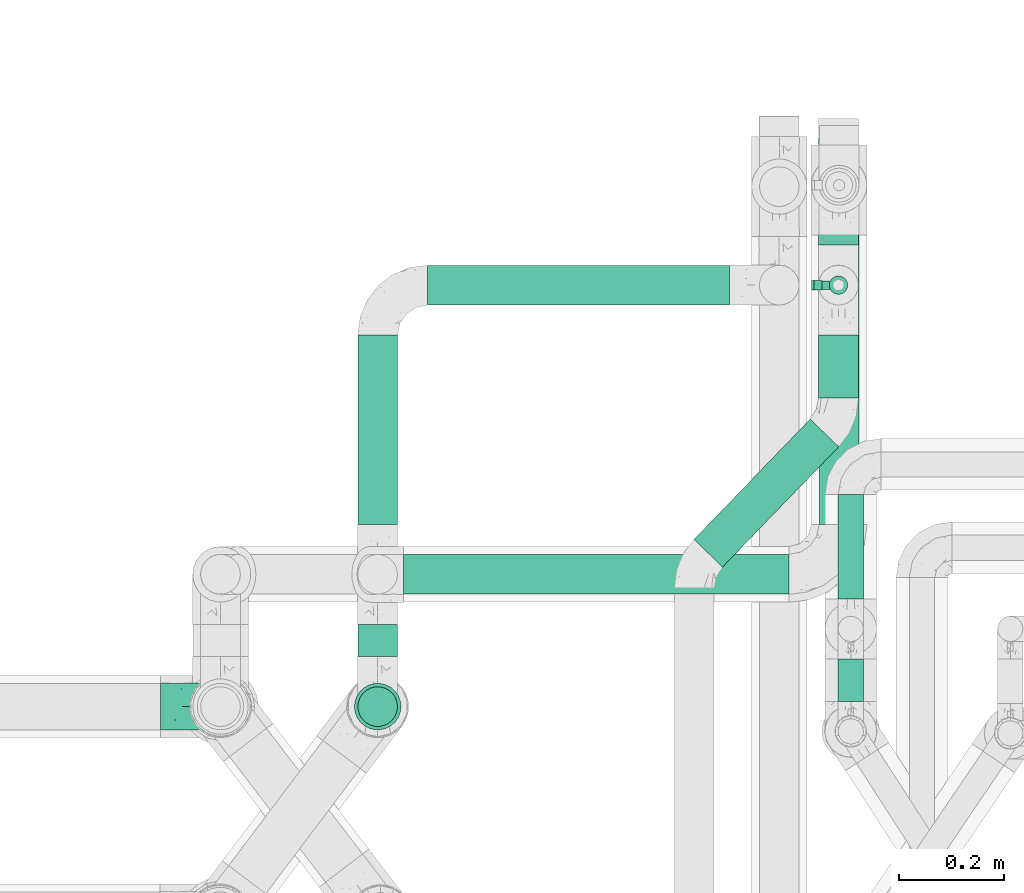
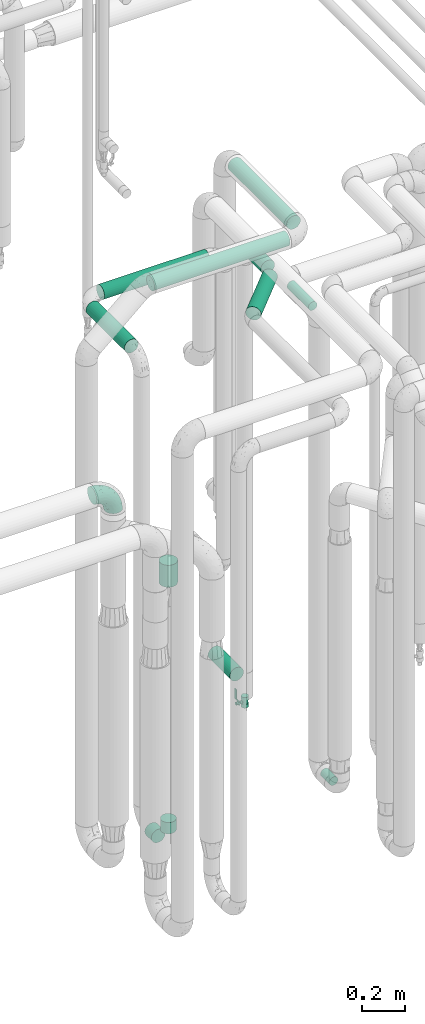
# One storey, part 670 of 827: 12 flow segments, 1 flow controller, 1 flow fitting.
"""IFC2X3 building model written with IfcOpenShell, lengths in millimetres."""

import ifcopenshell
import ifcopenshell.guid

model = None  # the IFC model being written
_history = None  # IfcOwnerHistory: only IFC2X3 demands one
_inside = {}  # id of a spatial element -> (the spatial element, [elements in it])
_under = {}  # id of a project, library or spatial element -> (it, [spatial elements below it])
_declared = {}  # id of a project -> (the project, [libraries it declares])
_typed = {}  # id of a type object -> (the type object, [elements of that type])
_made_of = {}  # id of a material, layer set ... -> (it, [elements and type objects made of it])


def new_model(schema):
    """Start an empty IFC model of exactly this schema.

    Asked for "IFC4X3", IfcOpenShell would pick the latest addendum, in which some entities
    have other attributes; the version numbers below select the first issue.
    IFC2X3 requires an IfcOwnerHistory on every rooted entity: one is made here for all.
    """
    global model, _history
    if schema == "IFC4X3":
        model = ifcopenshell.file(schema_version=(4, 3, 0, 0))
    else:
        model = ifcopenshell.file(schema=schema)
    _inside.clear()
    _under.clear()
    _declared.clear()
    _typed.clear()
    _made_of.clear()
    _history = None
    if model.schema == "IFC2X3":
        org = make("IfcOrganization", Name="unknown")
        user = make(
            "IfcPersonAndOrganization",
            ThePerson=make("IfcPerson", FamilyName="unknown"),
            TheOrganization=org,
        )
        app = make(
            "IfcApplication",
            ApplicationDeveloper=org,
            Version="unknown",
            ApplicationFullName="unknown",
            ApplicationIdentifier="unknown",
        )
        _history = make(
            "IfcOwnerHistory",
            OwningUser=user,
            OwningApplication=app,
            ChangeAction="ADDED",
            CreationDate=0,
        )
    return model


def make(cls, **values):
    """One entity of the class cls with the attributes given. An attribute that is None is left unset."""
    return model.create_entity(
        cls, **{name: value for name, value in values.items() if value is not None}
    )


def entity(cls, *values):
    """Any entity or typed value of the class cls, its attributes in the order of the schema. None: left unset."""
    e = model.create_entity(cls)
    for i, value in enumerate(values):
        if value is not None:
            e[i] = value
    return e


def rooted(cls, **values):
    """An entity with a GlobalId (a new one), such as an element, a storey or a relation."""
    return make(cls, GlobalId=ifcopenshell.guid.new(), OwnerHistory=_history, **values)


def si_unit(unit_type, name, prefix=None):
    """IfcSIUnit, for example si_unit("LENGTHUNIT", "METRE", prefix="MILLI")."""
    return make("IfcSIUnit", UnitType=unit_type, Prefix=prefix, Name=name)


def converted_unit(unit_type, name, factor, base, dimensions=None, offset=None):
    """IfcConversionBasedUnit, such as the inch: factor (a typed value) times the base unit."""
    return make(
        "IfcConversionBasedUnit"
        if offset is None
        else "IfcConversionBasedUnitWithOffset",
        ConversionOffset=offset,
        Dimensions=None
        if dimensions is None
        else entity("IfcDimensionalExponents", *dimensions),
        UnitType=unit_type,
        Name=name,
        ConversionFactor=make(
            "IfcMeasureWithUnit", ValueComponent=factor, UnitComponent=base
        ),
    )


def derived_unit(unit_type, elements):
    """IfcDerivedUnit: a product of units, each with its exponent."""
    return make(
        "IfcDerivedUnit",
        Elements=[
            make("IfcDerivedUnitElement", Unit=unit, Exponent=power)
            for unit, power in elements
        ],
        UnitType=unit_type,
    )


def assignment(units):
    """IfcUnitAssignment: the units of a project."""
    return None if units is None else make("IfcUnitAssignment", Units=units)


def point(xyz):
    """IfcCartesianPoint."""
    return None if xyz is None else make("IfcCartesianPoint", Coordinates=xyz)


def direction(xyz):
    """IfcDirection."""
    return None if xyz is None else make("IfcDirection", DirectionRatios=xyz)


def frame(location, z_axis=None, x_axis=None):
    """IfcAxis2Placement3D, a coordinate frame: its origin and axes. An axis left out is left unset."""
    return make(
        "IfcAxis2Placement3D",
        Location=point(location),
        Axis=direction(z_axis),
        RefDirection=direction(x_axis),
    )


def frame_2d(location, x_axis=None):
    """IfcAxis2Placement2D, a coordinate frame in the plane: its origin and x axis."""
    return make(
        "IfcAxis2Placement2D", Location=point(location), RefDirection=direction(x_axis)
    )


def origin():
    """The frame at (0, 0, 0) with its axes left unset."""
    return frame((0.0, 0.0, 0.0))


def origin_2d_with_axis():
    """The frame at (0, 0) in the plane with the x axis (1, 0) written out."""
    return frame_2d((0.0, 0.0), x_axis=(1.0, 0.0))


def place(relative_to, where):
    """IfcLocalPlacement: puts the frame where relative to a parent placement (None: the world)."""
    return make(
        "IfcLocalPlacement", PlacementRelTo=relative_to, RelativePlacement=where
    )


def context(
    kind, dimensions, precision=None, world=None, true_north=None, identifier=None
):
    """IfcGeometricRepresentationContext, for example the 3D "Model" context."""
    return make(
        "IfcGeometricRepresentationContext",
        ContextIdentifier=identifier,
        ContextType=kind,
        CoordinateSpaceDimension=dimensions,
        Precision=precision,
        WorldCoordinateSystem=world,
        TrueNorth=true_north,
    )


def subcontext(parent, identifier, kind, view, scale=None):
    """IfcGeometricRepresentationSubContext, for example "Body" below "Model"."""
    return make(
        "IfcGeometricRepresentationSubContext",
        ContextIdentifier=identifier,
        ContextType=kind,
        ParentContext=parent,
        TargetScale=scale,
        TargetView=view,
    )


def project(units=None, contexts=None):
    """IfcProject with its units and contexts."""
    return rooted(
        "IfcProject",
        Name="project",
        RepresentationContexts=contexts,
        UnitsInContext=assignment(units),
    )


def spatial(cls, under=None, at=None, **own):
    """A site, building, storey or space (cls), placed at a placement, below another one or the project."""
    s = rooted(cls, ObjectPlacement=at, **own)
    if under is not None:
        _under.setdefault(under.id(), (under, []))[1].append(s)
    return s


def polyline(points):
    """IfcPolyline through the points."""
    return make("IfcPolyline", Points=[point(p) for p in points])


def profile(cls, at=None, kind="AREA", **sizes):
    """A parametric profile (cls). Its sizes go by their IFC names, for example OverallWidth=200.0."""
    return make(cls, ProfileType=kind, Position=at, **sizes)


def circle(**sizes):
    """IfcCircleProfileDef."""
    return profile("IfcCircleProfileDef", **sizes)


def outline(outer, holes=None, kind="AREA"):
    """IfcArbitraryClosedProfileDef: a profile drawn as a closed curve; with holes, ...WithVoids."""
    if holes is None:
        return make("IfcArbitraryClosedProfileDef", ProfileType=kind, OuterCurve=outer)
    return make(
        "IfcArbitraryProfileDefWithVoids",
        ProfileType=kind,
        OuterCurve=outer,
        InnerCurves=holes,
    )


def extrude(swept, where, along, depth):
    """IfcExtrudedAreaSolid: the profile swept, set in the frame where, extruded along a direction by depth."""
    return make(
        "IfcExtrudedAreaSolid",
        SweptArea=swept,
        Position=where,
        ExtrudedDirection=direction(along),
        Depth=depth,
    )


def faces_of(points, faces, orient=None, outer=None):
    """IfcFace entities. A face is a list of loops; a loop is a list of indices into points, from 0.

    orient and outer hold one flag for each loop. By default every Orientation is true, the
    first loop of a face is its IfcFaceOuterBound and the others are IfcFaceBound.
    """
    made = []
    for i, loops in enumerate(faces):
        bounds = []
        for j, loop in enumerate(loops):
            is_outer = j == 0 if outer is None else outer[i][j]
            bounds.append(
                make(
                    "IfcFaceOuterBound" if is_outer else "IfcFaceBound",
                    Bound=make("IfcPolyLoop", Polygon=[points[k] for k in loop]),
                    Orientation=True if orient is None else orient[i][j],
                )
            )
        made.append(make("IfcFace", Bounds=bounds))
    return made


def faceted_brep(points, faces, orient=None, outer=None, voids=None):
    """IfcFacetedBrep: a solid bounded by flat faces; with voids (closed shells), ...WithVoids."""
    shared = [point(p) for p in points]
    hull = make("IfcClosedShell", CfsFaces=faces_of(shared, faces, orient, outer))
    if voids is None:
        return make("IfcFacetedBrep", Outer=hull)
    return make(
        "IfcFacetedBrepWithVoids",
        Outer=hull,
        Voids=[
            make(cls, CfsFaces=faces_of(shared, fs, o, b)) for cls, fs, o, b in voids
        ],
    )


def shape(context_of_items, identifier, shape_type, items):
    """IfcShapeRepresentation: the items that make up one representation, for example the "Body"."""
    return make(
        "IfcShapeRepresentation",
        ContextOfItems=context_of_items,
        RepresentationIdentifier=identifier,
        RepresentationType=shape_type,
        Items=items,
    )


def source(mapping_origin, context_of_items, identifier, shape_type, items):
    """IfcRepresentationMap: a shape defined once, which mapped items show again and again."""
    return make(
        "IfcRepresentationMap",
        MappingOrigin=mapping_origin,
        MappedRepresentation=shape(context_of_items, identifier, shape_type, items),
    )


def transform(
    local_origin,
    x_axis=None,
    y_axis=None,
    z_axis=None,
    scale=None,
    scale2=None,
    scale3=None,
    uniform=True,
):
    """IfcCartesianTransformationOperator3D, or its non-uniform kind. x_axis, y_axis, z_axis: its Axis1, 2, 3."""
    if uniform:
        return make(
            "IfcCartesianTransformationOperator3D",
            Axis1=direction(x_axis),
            Axis2=direction(y_axis),
            LocalOrigin=point(local_origin),
            Scale=scale,
            Axis3=direction(z_axis),
        )
    return make(
        "IfcCartesianTransformationOperator3DnonUniform",
        Axis1=direction(x_axis),
        Axis2=direction(y_axis),
        LocalOrigin=point(local_origin),
        Scale=scale,
        Axis3=direction(z_axis),
        Scale2=scale2,
        Scale3=scale3,
    )


def mapped(mapping_source, mapping_target):
    """IfcMappedItem: shows the shape of a source again, moved by a transform."""
    return make(
        "IfcMappedItem", MappingSource=mapping_source, MappingTarget=mapping_target
    )


def material(Name=None, Category=None):
    """IfcMaterial."""
    return make("IfcMaterial", Name=Name, Category=Category)


def material_list(materials):
    """IfcMaterialList."""
    return make("IfcMaterialList", Materials=materials)


def made_of(thing, what):
    """Note that an element or type object is made of a material, layer set ...; save() writes the relation."""
    if what is not None:
        _made_of.setdefault(what.id(), (what, []))[1].append(thing)
    return thing


def type_object(cls, material=None, **own):
    """A type object (cls), such as IfcWallType, which elements share."""
    return made_of(rooted(cls, **own), material)


def type_shapes(of_type, sources):
    """Give a type object the sources (RepresentationMaps) that its elements show as mapped items."""
    of_type.RepresentationMaps = sources


def element(
    cls,
    number,
    at=None,
    inside=None,
    cuts=None,
    type_object=None,
    material=None,
    context=None,
    identifier="Body",
    shape_type=None,
    held_by="IfcProductDefinitionShape",
    body=None,
    shapes=None,
    **own,
):
    """One element of the class cls, such as IfcWall. Its Tag is "e" and its number.

    at: its placement. inside: the storey or other place that contains it. cuts: it is an
    opening in that element (IfcRelVoidsElement). A single representation is given by context,
    identifier, shape_type and body (its items); several are given by shapes. held_by: the class
    of the entity that holds the representations. save() writes the other relations.
    """
    e = rooted(cls, Tag="e%d" % number, ObjectPlacement=at, **own)
    if body is not None:
        shapes = [shape(context, identifier, shape_type, body)]
    if shapes is not None:
        e.Representation = make(held_by, Representations=shapes)
    if inside is not None:
        _inside.setdefault(inside.id(), (inside, []))[1].append(e)
    if cuts is not None:
        rooted(
            "IfcRelVoidsElement", RelatingBuildingElement=cuts, RelatedOpeningElement=e
        )
    if type_object is not None:
        _typed.setdefault(type_object.id(), (type_object, []))[1].append(e)
    return made_of(e, material)


def aggregate(whole, parts):
    """IfcRelAggregates: a whole, such as a stair, and the parts it consists of."""
    return rooted("IfcRelAggregates", RelatingObject=whole, RelatedObjects=parts)


def save(model, path):
    """Write the relations noted so far, then the file.

    IfcRelAggregates (storeys below a building ...), IfcRelContainedInSpatialStructure (elements
    in a storey), IfcRelDefinesByType, IfcRelAssociatesMaterial and IfcRelDeclares: one each for
    every whole, place, type object, material and project.
    """
    for whole, parts in _under.values():
        aggregate(whole, parts)
    for where, things in _inside.values():
        rooted(
            "IfcRelContainedInSpatialStructure",
            RelatedElements=things,
            RelatingStructure=where,
        )
    for kind, things in _typed.values():
        rooted("IfcRelDefinesByType", RelatedObjects=things, RelatingType=kind)
    for what, things in _made_of.values():
        rooted("IfcRelAssociatesMaterial", RelatedObjects=things, RelatingMaterial=what)
    for by, libraries in _declared.values():
        rooted("IfcRelDeclares", RelatingContext=by, RelatedDefinitions=libraries)
    model.write(path)


model = new_model("IFC2X3")

# Units and contexts
model_context = context("Model", 3, precision=0.01, world=origin(), true_north=direction((6.12303176911189e-17, 1.0)))
body_context = subcontext(model_context, "Body", "Model", "MODEL_VIEW")
ifc_project = project(units=[si_unit("LENGTHUNIT", "METRE", prefix="MILLI"), si_unit("AREAUNIT", "SQUARE_METRE"), si_unit("VOLUMEUNIT", "CUBIC_METRE"), converted_unit("PLANEANGLEUNIT", "DEGREE", entity("IfcRatioMeasure", 0.0174532925199433), si_unit("PLANEANGLEUNIT", "RADIAN"), dimensions=[0, 0, 0, 0, 0, 0, 0]), si_unit("MASSUNIT", "GRAM", prefix="KILO"), derived_unit("MASSDENSITYUNIT", [(si_unit("MASSUNIT", "GRAM", prefix="KILO"), 1), (si_unit("LENGTHUNIT", "METRE"), -3)]), derived_unit("MOMENTOFINERTIAUNIT", [(si_unit("LENGTHUNIT", "METRE"), 4)]), si_unit("TIMEUNIT", "SECOND"), si_unit("FREQUENCYUNIT", "HERTZ"), si_unit("THERMODYNAMICTEMPERATUREUNIT", "DEGREE_CELSIUS"), derived_unit("THERMALTRANSMITTANCEUNIT", [(si_unit("MASSUNIT", "GRAM", prefix="KILO"), 1), (si_unit("THERMODYNAMICTEMPERATUREUNIT", "KELVIN"), -1), (si_unit("TIMEUNIT", "SECOND"), -3)]), derived_unit("VOLUMETRICFLOWRATEUNIT", [(si_unit("LENGTHUNIT", "METRE"), 3), (si_unit("TIMEUNIT", "SECOND"), -1)]), derived_unit("MASSFLOWRATEUNIT", [(si_unit("MASSUNIT", "GRAM", prefix="KILO"), 1), (si_unit("TIMEUNIT", "SECOND"), -1)]), derived_unit("ROTATIONALFREQUENCYUNIT", [(si_unit("TIMEUNIT", "SECOND"), -1)]), si_unit("ELECTRICCURRENTUNIT", "AMPERE"), si_unit("ELECTRICVOLTAGEUNIT", "VOLT"), si_unit("POWERUNIT", "WATT"), si_unit("FORCEUNIT", "NEWTON", prefix="KILO"), si_unit("ILLUMINANCEUNIT", "LUX"), si_unit("LUMINOUSFLUXUNIT", "LUMEN"), si_unit("LUMINOUSINTENSITYUNIT", "CANDELA"), derived_unit("USERDEFINED", [(si_unit("MASSUNIT", "GRAM", prefix="KILO"), -1), (si_unit("LENGTHUNIT", "METRE"), -2), (si_unit("TIMEUNIT", "SECOND"), 3), (si_unit("LUMINOUSFLUXUNIT", "LUMEN"), 1)]), derived_unit("LINEARVELOCITYUNIT", [(si_unit("LENGTHUNIT", "METRE"), 1), (si_unit("TIMEUNIT", "SECOND"), -1)]), si_unit("PRESSUREUNIT", "PASCAL"), derived_unit("USERDEFINED", [(si_unit("LENGTHUNIT", "METRE"), -2), (si_unit("MASSUNIT", "GRAM", prefix="KILO"), 1), (si_unit("TIMEUNIT", "SECOND"), -2)]), derived_unit("LINEARFORCEUNIT", [(si_unit("MASSUNIT", "GRAM", prefix="KILO"), 1), (si_unit("LENGTHUNIT", "METRE"), 1), (si_unit("TIMEUNIT", "SECOND"), -2), (si_unit("LENGTHUNIT", "METRE"), -1)]), derived_unit("PLANARFORCEUNIT", [(si_unit("MASSUNIT", "GRAM", prefix="KILO"), 1), (si_unit("LENGTHUNIT", "METRE"), 1), (si_unit("TIMEUNIT", "SECOND"), -2), (si_unit("LENGTHUNIT", "METRE"), -2)])], contexts=[model_context])

# Site, building, storey
site_placement = place(None, origin())
site = spatial("IfcSite", under=ifc_project, at=site_placement, CompositionType="ELEMENT")
building_placement = place(site_placement, origin())
building = spatial("IfcBuilding", under=site, at=building_placement, CompositionType="ELEMENT")
storey_placement = place(building_placement, frame((0.0, 0.0, 28200.0)))
storey = spatial("IfcBuildingStorey", under=building, at=storey_placement, Name="08", CompositionType="ELEMENT", Elevation=28200.0)

# Flow segments
pipe_segment_type = type_object("IfcPipeSegmentType", PredefinedType="NOTDEFINED")
flow_segment_1_placement = place(storey_placement, frame((46667.19, 14296.53, 374.4)))
element("IfcFlowSegment", 1, at=flow_segment_1_placement, inside=storey, type_object=pipe_segment_type, context=body_context, shape_type="SweptSolid", body=[
    extrude(circle(Radius=24.0, at=origin_2d_with_axis()), frame((25.6, 0.0, 25.6), z_axis=(0.0, 1.0, 0.0), x_axis=(-1.0, 0.0, 0.0)), (0.0, 0.0, 1.0), 81.0000000000119),
])
flow_segment_2_placement = place(storey_placement, frame((45753.73, 14381.62, 310.65)))
element("IfcFlowSegment", 2, at=flow_segment_2_placement, inside=storey, type_object=pipe_segment_type, context=body_context, shape_type="SweptSolid", body=[
    extrude(circle(Radius=37.75, at=origin_2d_with_axis()), frame((39.35, 0.0, 39.35), z_axis=(0.0, 1.0, 0.0), x_axis=(-1.0, 0.0, 0.0)), (0.0, 0.0, 1.0), 61.4604775255131),
])
flow_segment_3_placement = place(storey_placement, frame((45753.73, 14247.27, 445.0)))
element("IfcFlowSegment", 3, at=flow_segment_3_placement, inside=storey, type_object=pipe_segment_type, context=body_context, shape_type="SweptSolid", body=[
    extrude(circle(Radius=37.75, at=origin_2d_with_axis()), frame((39.35, 39.35, 0.0), z_axis=(0.0, 0.0, 1.0), x_axis=(-1.0, 0.0, 0.0)), (0.0, 0.0, 1.0), 64.9999999999982),
])
flow_segment_4_placement = place(storey_placement, frame((46667.19, 14491.53, 2974.4)))
element("IfcFlowSegment", 4, at=flow_segment_4_placement, inside=storey, type_object=pipe_segment_type, context=body_context, shape_type="SweptSolid", body=[
    extrude(circle(Radius=24.0, at=origin_2d_with_axis()), frame((25.6, 0.0, 25.6), z_axis=(0.0, 1.0, 0.0), x_axis=(1.0, 0.0, 0.0)), (0.0, 0.0, 1.0), 198.500000000011),
])
flow_segment_5_placement = place(storey_placement, frame((46392.95, 14550.37, 2960.65)))
element("IfcFlowSegment", 5, at=flow_segment_5_placement, inside=storey, type_object=pipe_segment_type, context=body_context, shape_type="SweptSolid", body=[
    extrude(circle(Radius=37.75, at=origin_2d_with_axis()), frame((28.75, 27.82, 39.35), z_axis=(0.694658370459035, 0.719339800338615, 0.0), x_axis=(0.719339800338615, -0.694658370459035, 0.0)), (0.0, 0.0, 1.0), 318.173784173211),
])
flow_segment_6_placement = place(storey_placement, frame((46630.04, 14873.06, 2960.65)))
element("IfcFlowSegment", 6, at=flow_segment_6_placement, inside=storey, type_object=pipe_segment_type, context=body_context, shape_type="SweptSolid", body=[
    extrude(circle(Radius=37.75, at=origin_2d_with_axis()), frame((39.35, 0.0, 39.35), z_axis=(0.0, 1.0, 0.0), x_axis=(1.0, 0.0, 0.0)), (0.0, 0.0, 1.0), 119.980797161493),
])
flow_segment_7_placement = place(storey_placement, frame((46630.04, 15164.04, 454.65)))
element("IfcFlowSegment", 7, at=flow_segment_7_placement, inside=storey, type_object=pipe_segment_type, context=body_context, shape_type="SweptSolid", body=[
    extrude(circle(Radius=37.75, at=origin_2d_with_axis()), frame((39.35, 0.0, 39.35), z_axis=(0.0, 1.0, 0.0), x_axis=(1.0, 0.0, 0.0)), (0.0, 0.0, 1.0), 203.199999999999),
])
flow_segment_8_placement = place(storey_placement, frame((45888.07, 15048.69, 2960.65)))
element("IfcFlowSegment", 8, at=flow_segment_8_placement, inside=storey, type_object=pipe_segment_type, context=body_context, shape_type="SweptSolid", body=[
    extrude(circle(Radius=37.75, at=origin_2d_with_axis()), frame((0.0, 39.35, 39.35), z_axis=(1.0, 0.0, 0.0), x_axis=(0.0, -1.0, 0.0)), (0.0, 0.0, 1.0), 573.565889836196),
])
flow_segment_9_placement = place(storey_placement, frame((45841.83, 14498.73, 3360.65)))
element("IfcFlowSegment", 9, at=flow_segment_9_placement, inside=storey, type_object=pipe_segment_type, context=body_context, shape_type="SweptSolid", body=[
    extrude(circle(Radius=37.75, at=origin_2d_with_axis()), frame((0.0, 39.35, 39.35), z_axis=(1.0, 0.0, 0.0), x_axis=(0.0, 1.0, 0.0)), (0.0, 0.0, 1.0), 733.72992241483),
])
flow_segment_10_placement = place(storey_placement, frame((46631.22, 14633.08, 3360.65)))
element("IfcFlowSegment", 10, at=flow_segment_10_placement, inside=storey, type_object=pipe_segment_type, context=body_context, shape_type="SweptSolid", body=[
    extrude(circle(Radius=37.75, at=origin_2d_with_axis()), frame((39.35, 0.0, 39.35), z_axis=(0.0, 1.0, 0.0), x_axis=(1.0, 0.0, 0.0)), (0.0, 0.0, 1.0), 550.000000000011),
])
flow_segment_11_placement = place(storey_placement, frame((45747.23, 14240.77, 1860.0)))
element("IfcFlowSegment", 11, at=flow_segment_11_placement, inside=storey, type_object=pipe_segment_type, context=body_context, shape_type="SweptSolid", body=[
    extrude(circle(Radius=44.25, at=origin_2d_with_axis()), frame((45.85, 45.85, 0.0)), (0.0, 0.0, 1.0), 126.000000000019),
])
flow_segment_12_placement = place(storey_placement, frame((45753.73, 14633.08, 2960.65)))
element("IfcFlowSegment", 12, at=flow_segment_12_placement, inside=storey, type_object=pipe_segment_type, context=body_context, shape_type="SweptSolid", body=[
    extrude(circle(Radius=37.75, at=origin_2d_with_axis()), frame((39.35, 0.0, 39.35), z_axis=(0.0, 1.0, 0.0), x_axis=(1.0, 0.0, 0.0)), (0.0, 0.0, 1.0), 359.958462474495),
])

# Flow controller
ifc_material = material()
ifc_material_list = material_list([ifc_material, ifc_material, ifc_material, ifc_material, ifc_material])
valve_type = type_object("IfcValveType", PredefinedType="NOTDEFINED", material=ifc_material_list)
shared_shape_1 = source(origin(), body_context, "Body", "SweptSolid", [
    extrude(circle(Radius=17.5, at=origin_2d_with_axis()), frame((-30.5, 0.0, 0.0), z_axis=(1.0, 0.0, 0.0), x_axis=(0.0, 1.0, 0.0)), (0.0, 0.0, 1.0), 20.3333333333333),
    extrude(circle(Radius=16.0, at=origin_2d_with_axis()), frame((-10.17, 0.0, 0.0), z_axis=(1.0, 0.0, 0.0), x_axis=(0.0, 1.0, 0.0)), (0.0, 0.0, 1.0), 20.3333333333333),
    extrude(circle(Radius=17.5, at=origin_2d_with_axis()), frame((10.17, 0.0, 0.0), z_axis=(1.0, 0.0, 0.0), x_axis=(0.0, 1.0, 0.0)), (0.0, 0.0, 1.0), 20.3333333333333),
    extrude(outline(polyline([(-38.75, -5.0), (-38.75, -10.0), (-17.92, -10.0), (2.08, 5.0), (56.25, 5.0), (56.25, 10.0), (0.42, 10.0), (-19.58, -5.0), (-38.75, -5.0)])), frame((28.75, -8.75, 41.5), z_axis=(0.0, -1.0, 0.0), x_axis=(1.0, 0.0, 0.0)), (0.0, 0.0, -1.0), 17.5),
    extrude(circle(Radius=8.0, at=origin_2d_with_axis()), origin(), (0.0, 0.0, 1.0), 49.0),
])
type_shapes(valve_type, [shared_shape_1])
flow_controller_placement = place(storey_placement, frame((46669.38, 15088.04, 387.5), z_axis=(-1.0, 0.0, 0.0), x_axis=(0.0, 0.0, 1.0)))
element("IfcFlowController", 13, at=flow_controller_placement, inside=storey, type_object=valve_type, material=ifc_material, context=body_context, shape_type="MappedRepresentation", body=[
    mapped(shared_shape_1, transform((0.0, 0.0, 0.0), scale=1.0)),
])

# Flow fitting
pipe_fitting_type = type_object("IfcPipeFittingType", Name="ADSK_1", PredefinedType="NOTDEFINED", material=ifc_material)
shared_shape_2 = source(origin(), body_context, "Body", "Brep", [
    faceted_brep([(-114.0, 22.22, -38.49), (-114.0, 11.5, -42.94), (-114.0, 0.0, -44.45), (-114.0, -11.5, -42.94), (-114.0, -22.23, -38.49), (-114.0, -31.43, -31.43), (-114.0, -38.49, -22.23), (-114.0, -42.94, -11.5), (-114.0, -44.45, 0.0), (-114.0, -42.94, 11.5), (-114.0, -38.49, 22.22), (-114.0, -31.43, 31.43), (-114.0, -22.23, 38.49), (-114.0, -11.5, 42.94), (-114.0, 0.0, 44.45), (-114.0, 11.5, 42.94), (-114.0, 22.22, 38.49), (-114.0, 31.43, 31.43), (-114.0, 38.49, 22.22), (-114.0, 42.94, 11.5), (-114.0, 44.45, 0.0), (-114.0, 42.94, -11.5), (-114.0, 38.49, -22.23), (-114.0, 31.43, -31.43), (0.0, 114.0, -44.45), (-11.5, 114.0, -42.94), (-22.22, 114.0, -38.49), (-31.43, 114.0, -31.43), (-38.49, 114.0, -22.23), (-42.94, 114.0, -11.5), (-44.45, 114.0, 0.0), (-42.94, 114.0, 11.5), (-38.49, 114.0, 22.22), (-31.43, 114.0, 31.43), (-22.22, 114.0, 38.49), (-11.5, 114.0, 42.94), (0.0, 114.0, 44.45), (11.5, 114.0, 42.94), (22.23, 114.0, 38.49), (31.43, 114.0, 31.43), (38.49, 114.0, 22.22), (42.94, 114.0, 11.5), (44.45, 114.0, 0.0), (42.94, 114.0, -11.5), (38.49, 114.0, -22.23), (31.43, 114.0, -31.43), (22.23, 114.0, -38.49), (11.5, 114.0, -42.94), (-24.5, -15.82, 8.24), (-7.18, -2.06, 7.97), (-13.53, -4.79, 15.72), (-92.03, -41.56, 0.0), (-77.08, -37.56, 14.57), (23.74, 74.96, 33.55), (-72.99, -39.05, 0.0), (-84.56, -15.6, 40.23), (-47.88, -6.37, 37.83), (-59.8, 2.77, 43.37), (-84.46, -33.54, 25.41), (16.69, 49.28, 31.02), (6.37, 47.88, 37.83), (3.35, 25.47, 29.77), (-47.43, 81.55, 19.51), (-74.96, -23.74, 33.55), (-46.77, -27.89, 11.23), (-53.88, -31.14, 0.0), (-87.05, 38.52, 28.81), (-63.44, 55.78, 24.79), (-93.24, 43.37, 18.58), (-16.67, 16.67, 37.64), (-25.47, -3.35, 29.77), (-17.2, 97.7, 41.53), (-7.42, 85.54, 44.3), (-67.09, 46.29, 31.23), (-18.08, 42.1, 44.06), (-32.93, 14.9, 42.17), (-11.54, 34.94, 41.69), (-95.7, 27.79, 36.14), (-88.55, -4.92, 43.79), (-2.77, 59.8, 43.37), (-87.65, 48.44, 9.87), (-81.01, 8.37, 44.32), (-37.63, 90.26, 28.6), (-51.29, 61.56, 30.59), (-29.32, 87.72, 36.52), (23.49, 49.5, 23.28), (8.19, 20.11, 19.18), (-70.06, 58.9, 9.01), (-87.38, 49.74, 0.0), (-88.15, 18.57, 41.8), (-7.96, 6.22, 24.33), (33.54, 84.46, 25.41), (37.56, 77.08, 14.57), (-58.37, 34.98, 40.92), (-62.38, 23.02, 43.45), (24.15, 39.93, 12.16), (31.14, 53.88, 0.0), (-58.13, 14.61, 44.45), (-37.17, 26.09, 44.37), (4.92, 88.55, 43.79), (-34.77, -23.22, 0.0), (-49.5, -23.49, 23.28), (41.56, 92.03, 0.0), (-57.83, 66.03, 19.12), (-71.84, 54.46, 17.06), (-46.46, 94.23, 8.51), (-49.74, 87.38, 0.0), (-38.96, 59.98, 38.88), (-55.29, 46.95, 36.83), (-64.82, 64.82, 0.0), (-55.88, 73.75, 10.01), (15.6, 84.56, 40.23), (-21.6, 76.38, 42.11), (-49.04, -15.53, 31.95), (-19.97, 55.59, 44.33), (-73.61, 33.95, 37.2), (-31.05, 58.14, 42.19), (-41.3, 41.3, 43.02), (-27.36, -11.22, 22.61), (9.28, 15.84, 8.73), (23.22, 34.77, 0.0), (39.05, 72.99, 0.0), (-1.96, 1.96, 0.0), (10.63, 18.37, 0.0), (-18.37, -10.63, 0.0), (-97.7, 17.2, -41.53), (9.28, 15.84, -8.73), (-13.53, -4.79, -15.72), (8.19, 20.11, -19.18), (-85.54, 7.42, -44.3), (-8.37, 81.01, -44.32), (-90.26, 37.63, -28.6), (-87.72, 29.32, -36.52), (-27.79, 95.7, -36.14), (-38.52, 87.05, -28.81), (-94.23, 46.46, -8.51), (-84.56, -15.6, -40.23), (-73.75, 55.88, -10.01), (-10.19, -4.86, -7.51), (-76.38, 21.6, -42.11), (-59.98, 38.96, -38.88), (-49.28, -16.69, -31.02), (-47.88, -6.37, -37.83), (-25.47, -3.35, -29.77), (-34.98, 58.37, -40.92), (-46.95, 55.29, -36.83), (-77.08, -37.56, -14.57), (-18.57, 88.15, -41.8), (-23.02, 62.38, -43.45), (-55.78, 63.44, -24.79), (-43.37, 93.24, -18.58), (-84.46, -33.54, -25.41), (-33.95, 73.61, -37.2), (-46.29, 67.09, -31.23), (-74.96, -23.74, -33.55), (-48.44, 87.65, -9.87), (-45.44, -27.06, -11.87), (-88.55, -4.92, -43.79), (-49.5, -23.49, -23.28), (-14.61, 58.13, -44.45), (-26.09, 37.17, -44.37), (15.6, 84.56, -40.23), (6.37, 47.88, -37.83), (-2.77, 59.8, -43.37), (-81.55, 47.43, -19.51), (33.54, 84.46, -25.41), (23.49, 49.5, -23.28), (23.74, 74.96, -33.55), (-42.1, 18.08, -44.06), (-14.9, 32.93, -42.17), (-34.94, 11.54, -41.69), (-61.56, 51.29, -30.59), (-27.36, -11.22, -22.61), (37.56, 77.08, -14.57), (4.92, 88.55, -43.79), (-59.8, 2.77, -43.37), (-66.03, 57.83, -19.12), (-54.46, 71.84, -17.06), (-55.59, 19.97, -44.33), (-58.9, 70.06, -9.01), (24.15, 39.93, -12.16), (15.53, 49.04, -31.95), (-58.14, 31.05, -42.19), (-41.3, 41.3, -43.02), (-16.67, 16.67, -37.64), (3.35, 25.47, -29.77), (-7.96, 6.22, -24.33), (-26.36, -16.33, -11.05)], [[[0, 1, 2, 3, 4, 5, 6, 7, 8, 9, 10, 11, 12, 13, 14, 15, 16, 17, 18, 19, 20, 21, 22, 23]], [[24, 25, 26, 27, 28, 29, 30, 31, 32, 33, 34, 35, 36, 37, 38, 39, 40, 41, 42, 43, 44, 45, 46, 47]], [[48, 49, 50]], [[51, 52, 9]], [[53, 39, 38]], [[9, 52, 10]], [[54, 52, 51]], [[55, 56, 57]], [[11, 10, 58]], [[59, 60, 61]], [[32, 31, 62]], [[63, 12, 11]], [[63, 55, 12]], [[64, 52, 65]], [[66, 67, 68]], [[69, 56, 70]], [[35, 71, 72]], [[67, 66, 73]], [[74, 75, 76]], [[16, 77, 17]], [[13, 78, 14]], [[76, 79, 74]], [[68, 80, 19]], [[18, 17, 66]], [[14, 78, 81]], [[20, 19, 80]], [[82, 83, 84]], [[85, 61, 86]], [[87, 88, 80]], [[18, 68, 19]], [[15, 89, 16]], [[14, 81, 15]], [[70, 90, 61]], [[17, 77, 66]], [[91, 85, 92]], [[93, 89, 94]], [[95, 96, 92]], [[84, 71, 34]], [[94, 97, 98]], [[37, 36, 99]], [[40, 39, 91]], [[40, 92, 41]], [[65, 100, 64]], [[91, 92, 40]], [[58, 101, 63]], [[92, 102, 41]], [[92, 85, 95]], [[67, 103, 104]], [[34, 33, 84]], [[105, 62, 31]], [[52, 58, 10]], [[106, 105, 30]], [[93, 107, 108]], [[106, 109, 110]], [[53, 111, 60]], [[84, 112, 71]], [[84, 107, 112]], [[33, 82, 84]], [[12, 55, 13]], [[113, 56, 63]], [[111, 38, 37]], [[34, 71, 35]], [[36, 35, 72]], [[112, 114, 72]], [[110, 105, 106]], [[111, 53, 38]], [[115, 108, 73]], [[89, 15, 81]], [[104, 87, 80]], [[110, 87, 103]], [[33, 32, 82]], [[116, 107, 117]], [[112, 116, 114]], [[99, 72, 79]], [[56, 55, 63]], [[78, 55, 57]], [[101, 118, 113]], [[56, 69, 75]], [[99, 111, 37]], [[79, 76, 60]], [[79, 60, 111]], [[60, 69, 61]], [[101, 58, 52]], [[63, 11, 58]], [[39, 53, 91]], [[85, 91, 53]], [[94, 89, 81]], [[77, 89, 115]], [[84, 83, 107]], [[93, 108, 115]], [[98, 114, 117]], [[79, 72, 114]], [[98, 117, 94]], [[98, 57, 75]], [[32, 62, 82]], [[83, 82, 62]], [[70, 113, 118]], [[61, 85, 59]], [[48, 64, 100]], [[95, 119, 120]], [[69, 70, 61]], [[70, 118, 90]], [[72, 99, 36]], [[111, 99, 79]], [[55, 78, 13]], [[81, 78, 57]], [[94, 81, 97]], [[93, 94, 117]], [[66, 68, 18]], [[80, 68, 104]], [[103, 87, 104]], [[80, 88, 20]], [[50, 49, 119]], [[95, 85, 86]], [[119, 95, 86]], [[121, 92, 96]], [[50, 119, 86]], [[119, 122, 123, 120]], [[110, 109, 87]], [[88, 87, 109]], [[62, 105, 110]], [[30, 105, 31]], [[81, 57, 97]], [[57, 98, 97]], [[107, 93, 117]], [[89, 93, 115]], [[107, 83, 108]], [[73, 108, 83]], [[67, 73, 83]], [[115, 73, 66]], [[103, 83, 62]], [[67, 104, 68]], [[83, 103, 67]], [[110, 103, 62]], [[89, 77, 16]], [[66, 77, 115]], [[56, 75, 57]], [[76, 75, 69]], [[60, 76, 69]], [[79, 114, 74]], [[114, 98, 74]], [[75, 74, 98]], [[9, 8, 51]], [[102, 92, 121]], [[102, 42, 41]], [[72, 71, 112]], [[52, 54, 65]], [[64, 48, 118]], [[101, 52, 64]], [[124, 122, 49]], [[118, 48, 50]], [[49, 48, 124]], [[119, 49, 122]], [[48, 100, 124]], [[114, 116, 117]], [[112, 107, 116]], [[101, 113, 63]], [[70, 56, 113]], [[64, 118, 101]], [[90, 50, 86]], [[50, 90, 118]], [[61, 90, 86]], [[85, 53, 59]], [[60, 59, 53]], [[95, 120, 96]], [[125, 1, 0]], [[126, 127, 128]], [[2, 1, 129]], [[24, 130, 25]], [[131, 132, 23]], [[27, 133, 134]], [[88, 135, 20]], [[136, 4, 3]], [[88, 109, 137]], [[138, 122, 124]], [[139, 132, 140]], [[141, 142, 143]], [[144, 140, 145]], [[125, 132, 139]], [[6, 146, 7]], [[144, 147, 148]], [[146, 51, 7]], [[134, 149, 150]], [[146, 6, 151]], [[152, 145, 153]], [[154, 4, 136]], [[154, 136, 142]], [[150, 155, 29]], [[43, 42, 102]], [[65, 146, 156]], [[0, 23, 132]], [[157, 3, 2]], [[146, 151, 158]], [[148, 159, 160]], [[161, 162, 163]], [[135, 164, 21]], [[165, 166, 167]], [[168, 169, 170]], [[147, 25, 130]], [[171, 132, 131]], [[155, 30, 29]], [[172, 141, 143]], [[134, 28, 27]], [[149, 134, 153]], [[173, 165, 44]], [[26, 25, 147]], [[22, 21, 164]], [[24, 174, 130]], [[133, 27, 26]], [[170, 175, 168]], [[24, 47, 174]], [[45, 167, 46]], [[28, 150, 29]], [[1, 125, 129]], [[156, 100, 65]], [[165, 45, 44]], [[161, 46, 167]], [[173, 44, 43]], [[6, 5, 151]], [[173, 102, 121]], [[137, 135, 88]], [[46, 161, 47]], [[102, 173, 43]], [[149, 176, 177]], [[172, 158, 141]], [[139, 178, 129]], [[154, 5, 4]], [[156, 146, 158]], [[106, 155, 179]], [[173, 96, 180]], [[181, 162, 167]], [[177, 179, 155]], [[137, 179, 176]], [[23, 22, 131]], [[182, 140, 183]], [[139, 182, 178]], [[157, 129, 175]], [[157, 136, 3]], [[175, 170, 142]], [[175, 142, 136]], [[142, 184, 143]], [[162, 161, 167]], [[174, 161, 163]], [[181, 166, 185]], [[162, 184, 169]], [[5, 154, 151]], [[158, 151, 154]], [[166, 165, 173]], [[167, 45, 165]], [[148, 147, 130]], [[133, 147, 152]], [[132, 171, 140]], [[144, 145, 152]], [[160, 178, 183]], [[175, 129, 178]], [[160, 183, 148]], [[160, 163, 169]], [[22, 164, 131]], [[171, 131, 164]], [[162, 185, 184]], [[186, 127, 172]], [[185, 128, 186]], [[156, 187, 100]], [[185, 166, 128]], [[143, 184, 185]], [[129, 157, 2]], [[136, 157, 175]], [[161, 174, 47]], [[130, 174, 163]], [[148, 130, 159]], [[144, 148, 183]], [[134, 150, 28]], [[155, 150, 177]], [[176, 179, 177]], [[155, 106, 30]], [[166, 180, 128]], [[128, 180, 126]], [[173, 180, 166]], [[126, 120, 123, 122]], [[120, 126, 180]], [[122, 138, 126]], [[137, 109, 179]], [[106, 179, 109]], [[164, 135, 137]], [[20, 135, 21]], [[130, 163, 159]], [[163, 160, 159]], [[140, 144, 183]], [[147, 144, 152]], [[140, 171, 145]], [[153, 145, 171]], [[149, 153, 171]], [[152, 153, 134]], [[176, 171, 164]], [[149, 177, 150]], [[171, 176, 149]], [[137, 176, 164]], [[147, 133, 26]], [[134, 133, 152]], [[162, 169, 163]], [[170, 169, 184]], [[142, 170, 184]], [[175, 178, 168]], [[178, 160, 168]], [[169, 168, 160]], [[51, 146, 54]], [[51, 8, 7]], [[132, 125, 0]], [[129, 125, 139]], [[156, 158, 172]], [[65, 54, 146]], [[178, 182, 183]], [[139, 140, 182]], [[158, 154, 141]], [[142, 141, 154]], [[186, 172, 143]], [[172, 127, 187]], [[185, 186, 143]], [[127, 186, 128]], [[187, 127, 138]], [[124, 100, 187]], [[126, 138, 127]], [[187, 138, 124]], [[172, 187, 156]], [[166, 181, 167]], [[185, 162, 181]], [[96, 173, 121]], [[96, 120, 180]]]),
])
type_shapes(pipe_fitting_type, [shared_shape_2])
flow_fitting_placement = place(storey_placement, frame((45494.22, 14286.62, 2500.0), z_axis=(0.0, 1.0, 0.0), x_axis=(1.0, 0.0, 0.0)))
element("IfcFlowFitting", 14, at=flow_fitting_placement, inside=storey, type_object=pipe_fitting_type, material=ifc_material, Name="ADSK_1", ObjectType="ADSK_1", context=body_context, shape_type="MappedRepresentation", body=[
    mapped(shared_shape_2, transform((0.0, 0.0, 0.0), scale=1.0)),
])

save(model, "model.ifc")
